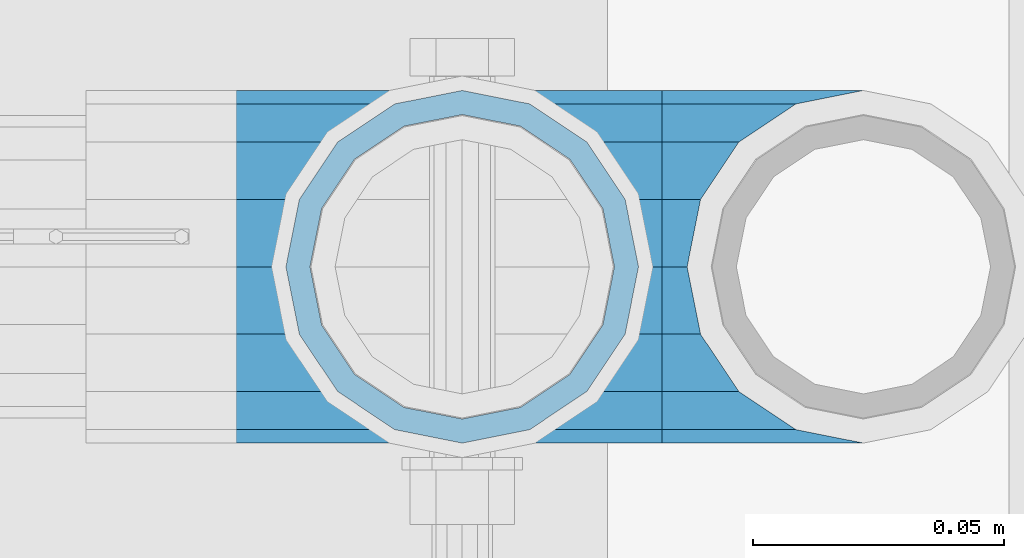
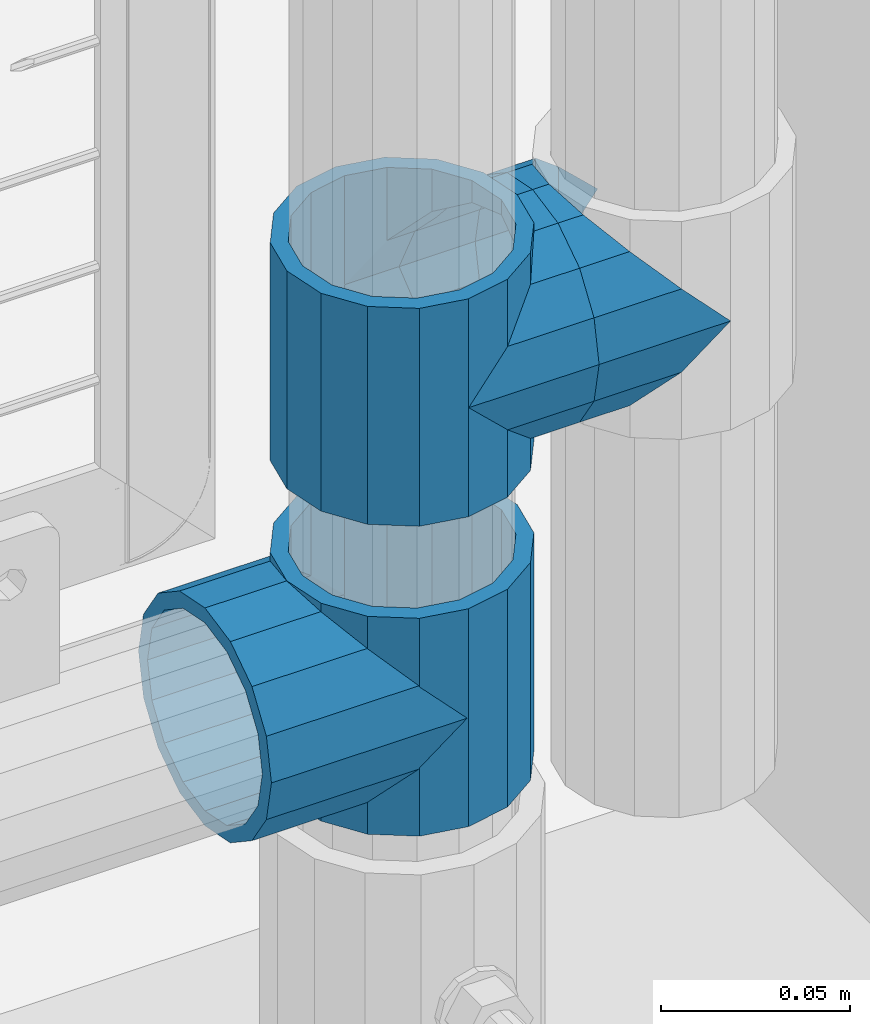
# One storey, part 162 of 240: 5 beams.
"""IFC2X3 building model written with IfcOpenShell, lengths in millimetres."""

from ifc_helpers import new_model, si_unit, frame, origin_with_axes, place, context, subcontext, project, spatial, faceted_brep, material, type_object, element, save


model = new_model("IFC2X3")

# Units and contexts
model_context = context("Model", 3, precision=1e-05, world=origin_with_axes())
body_context = subcontext(model_context, "Body", "Model", "MODEL_VIEW")
ifc_project = project(units=[si_unit("LENGTHUNIT", "METRE", prefix="MILLI"), si_unit("AREAUNIT", "SQUARE_METRE"), si_unit("VOLUMEUNIT", "CUBIC_METRE"), si_unit("MASSUNIT", "GRAM", prefix="KILO"), si_unit("TIMEUNIT", "SECOND"), si_unit("PLANEANGLEUNIT", "RADIAN"), si_unit("SOLIDANGLEUNIT", "STERADIAN"), si_unit("THERMODYNAMICTEMPERATUREUNIT", "DEGREE_CELSIUS"), si_unit("LUMINOUSINTENSITYUNIT", "LUMEN")], contexts=[model_context])

# Site, building, storey
site_placement = place(None, origin_with_axes())
site = spatial("IfcSite", under=ifc_project, at=site_placement, CompositionType="ELEMENT")
building_placement = place(site_placement, origin_with_axes())
building = spatial("IfcBuilding", under=site, at=building_placement, Name="Standard", CompositionType="ELEMENT")
storey_placement = place(building_placement, origin_with_axes())
storey = spatial("IfcBuildingStorey", under=building, at=storey_placement, Name="Undefined", CompositionType="ELEMENT", Elevation=0.0)

# Beams
ifc_material = material(Name="Misc_Undefined")
beam_type = type_object("IfcBeamType", PredefinedType="NOTDEFINED")
beam_1_placement = place(storey_placement, frame((55881.0, 34664.5, 298.670000000001), z_axis=(0.0, 1.0, 0.0), x_axis=(-1.0, 0.0, 0.0)))
element("IfcBeam", 1, at=beam_1_placement, inside=storey, type_object=beam_type, material=ifc_material, context=body_context, shape_type="Brep", body=[
    faceted_brep([(0.0, 0.0, -35.1500000000015), (13.4513226476338, -13.4513226476329, -32.4743655677739), (13.4513226476338, 13.4513226476329, -32.4743655677739), (27.1226768591005, -21.4606908090117, 21.4606908090136), (32.4743655677739, -26.8123795176712, 13.4513226476338), (32.4743655677739, -32.4743655677717, 13.4513226476338), (24.8548033587067, -24.8548033587072, 24.8548033587067), (24.8548033587067, -16.3810424080078, 24.8548033587067), (32.8397438117099, -28.0397438117175, 11.6144421722784), (35.1500000000015, -30.35, 0.0), (35.1500000000015, -35.15, 0.0), (32.4743655677739, -26.8123795176712, -13.4513226476338), (32.4743655677739, -32.4743655677717, -13.4513226476338), (32.8397438117172, -28.0397438117175, -11.6144421722784), (24.8548033587067, -16.3810424079947, -24.8548033587067), (24.8548033587067, -24.8548033587072, -24.8548033587067), (27.1226768591223, -21.4606908090117, -21.4606908090136), (20.0882031229994, -11.6144421722805, -28.0397438117143), (16.6306603983758, 0.0, -30.3499999999985), (20.0882031229994, 11.6144421722805, -28.0397438117143), (24.8548033587067, 16.3810424080013, -24.8548033587067), (24.8548033587067, 24.8548033587072, -24.8548033587067), (27.1226768591223, 21.4606908090117, -21.4606908090136), (32.4743655677739, 26.8123795176712, -13.4513226476338), (32.4743655677739, 32.4743655677717, -13.4513226476338), (32.8397438117172, 28.0397438117175, -11.6144421722784), (35.1500000000015, 30.35, 0.0), (35.1500000000015, 35.15, 0.0), (32.8397438117099, 28.0397438117175, 11.6144421722784), (32.4743655677739, 26.8123795176755, 13.4513226476338), (32.4743655677739, 32.4743655677717, 13.4513226476338), (27.1226768591005, 21.4606908090117, 21.4606908090136), (24.8548033587067, 16.3810424080013, 24.8548033587067), (24.8548033587067, 24.8548033587072, 24.8548033587067), (0.0, 0.0, 35.1500000000015), (13.4513226476338, 13.4513226476329, 32.4743655677739), (13.4513226476338, -13.4513226476329, 32.4743655677739), (20.0882031229849, 11.6144421722805, 28.0397438117143), (16.6306603983685, 0.0, 30.3499999999985), (20.0882031229849, -11.6144421722805, 28.0397438117143), (60.1500000000015, -35.15, 0.0), (60.1500000000015, -32.4743655677717, 13.4513226476338), (60.1500000000015, -24.8548033587072, 24.8548033587067), (60.1500000000015, -13.4513226476329, 32.4743655677739), (60.1500000000015, 0.0, 35.1500000000015), (60.1500000000015, -24.8548033587072, -24.8548033587067), (60.1500000000015, -32.4743655677717, -13.4513226476338), (60.1500000000015, -13.4513226476329, -32.4743655677739), (60.1500000000015, 0.0, -35.1500000000015), (60.1500000000015, 13.4513226476329, -32.4743655677739), (60.1500000000015, 24.8548033587072, -24.8548033587067), (60.1500000000015, 32.4743655677717, -13.4513226476338), (60.1500000000015, 35.15, 0.0), (60.1500000000015, 32.4743655677717, 13.4513226476338), (60.1500000000015, 24.8548033587072, 24.8548033587067), (60.1500000000015, 13.4513226476329, 32.4743655677739), (60.1500000000015, -21.4606908090117, 21.4606908090136), (60.1500000000015, -11.6144421722805, 28.0397438117143), (60.1500000000015, 0.0, 30.3499999999985), (60.1500000000015, 11.6144421722805, 28.0397438117143), (60.1500000000015, 21.4606908090117, 21.4606908090136), (60.1500000000015, 28.0397438117175, 11.6144421722784), (60.1500000000015, 30.35, 0.0), (60.1500000000015, 28.0397438117175, -11.6144421722784), (60.1500000000015, 21.4606908090117, -21.4606908090136), (60.1500000000015, 11.6144421722805, -28.0397438117143), (60.1500000000015, 0.0, -30.3499999999985), (60.1500000000015, -11.6144421722805, -28.0397438117143), (60.1500000000015, -21.4606908090117, -21.4606908090136), (60.1500000000015, -28.0397438117175, -11.6144421722784), (60.1500000000015, -30.35, 0.0), (60.1500000000015, -28.0397438117175, 11.6144421722784)], [[[0, 1, 2]], [[3, 4, 5, 6, 7]], [[8, 9, 10, 5, 4]], [[11, 12, 10, 9, 13]], [[14, 15, 12, 11, 16]], [[2, 1, 15, 14, 17, 18, 19, 20, 21]], [[21, 20, 22, 23, 24]], [[24, 23, 25, 26, 27]], [[27, 26, 28, 29, 30]], [[30, 29, 31, 32, 33]], [[34, 35, 36]], [[33, 32, 37, 38, 39, 7, 6, 36, 35]], [[40, 41, 5, 10]], [[41, 42, 6, 5]], [[42, 43, 36, 6]], [[43, 44, 34, 36]], [[45, 46, 12, 15]], [[47, 45, 15, 1]], [[48, 47, 1, 0]], [[49, 48, 0, 2]], [[50, 49, 2, 21]], [[51, 50, 21, 24]], [[52, 51, 24, 27]], [[53, 52, 27, 30]], [[54, 53, 30, 33]], [[55, 54, 33, 35]], [[44, 55, 35, 34]], [[46, 40, 10, 12]], [[45, 47, 48, 49, 50, 51, 52, 53, 54, 55, 44, 43, 42, 41, 40, 46], [56, 57, 58, 59, 60, 61, 62, 63, 64, 65, 66, 67, 68, 69, 70, 71]], [[59, 58, 38, 37]], [[31, 60, 59, 37, 32]], [[28, 61, 60, 31, 29]], [[62, 61, 28, 26]], [[63, 62, 26, 25]], [[64, 63, 25, 23, 22]], [[65, 64, 22, 20, 19]], [[66, 65, 19, 18]], [[67, 66, 18, 17]], [[16, 68, 67, 17, 14]], [[13, 69, 68, 16, 11]], [[70, 69, 13, 9]], [[71, 70, 9, 8]], [[56, 71, 8, 4, 3]], [[57, 56, 3, 7, 39]], [[58, 57, 39, 38]]]),
])
beam_2_placement = place(storey_placement, frame((55881.0, 34664.5, 333.820000000001), z_axis=(1.0, 0.0, 0.0), x_axis=(0.0, 0.0, -1.0)))
element("IfcBeam", 2, at=beam_2_placement, inside=storey, type_object=beam_type, material=ifc_material, context=body_context, shape_type="Brep", body=[
    faceted_brep([(46.7644421722801, 28.0397438117143, -11.6144421722784), (46.7644421722801, 28.0397438117143, -20.0882031229849), (51.5310424079941, 24.8548033587067, -24.8548033587067), (56.6106908090114, 21.4606908090136, -27.1226768591077), (56.6106908090114, 21.4606908090136, -21.4606908090136), (61.9623795176703, 13.4513226476338, -32.4743655677739), (63.1897438117172, 11.6144421722784, -32.8397438117172), (63.1897438117172, 11.6144421722784, -28.0397438117143), (65.4999999999997, 0.0, -35.1500000000015), (65.4999999999997, 0.0, -30.3499999999985), (63.1897438117172, -11.6144421722784, -32.8397438117245), (63.1897438117172, -11.6144421722784, -28.0397438117143), (61.9623795176703, -13.4513226476338, -32.4743655677739), (56.6106908090114, -21.4606908090136, -27.1226768591223), (56.6106908090114, -21.4606908090136, -21.4606908090136), (51.5310424080006, -24.8548033587067, -24.8548033587067), (46.7644421722801, -28.0397438117143, -20.0882031229994), (46.7644421722801, -28.0397438117143, -11.6144421722784), (35.1499999999996, -30.3499999999985, -16.6306603983758), (35.1500000000015, -30.35, 0.0), (23.5355578277191, -28.0397438117143, -20.0882031229994), (23.5355578277191, -28.0397438117143, -11.6144421722784), (18.7689575919987, -24.8548033587067, -24.8548033587067), (13.6893091909879, -21.4606908090136, -27.1226768591223), (13.6893091909879, -21.4606908090136, -21.4606908090136), (8.33762048232455, -13.4513226476338, -32.4743655677739), (7.11025618828211, -11.6144421722784, -32.8397438117245), (7.11025618828211, -11.6144421722784, -28.0397438117143), (4.79999999999961, 0.0, -35.1500000000015), (4.79999999999961, 0.0, -30.3499999999985), (7.11025618828211, 11.6144421722784, -32.8397438117172), (7.11025618828211, 11.6144421722784, -28.0397438117143), (8.33762048232893, 13.4513226476338, -32.4743655677739), (13.6893091909879, 21.4606908090136, -27.1226768591077), (13.6893091909879, 21.4606908090136, -21.4606908090136), (18.7689575919921, 24.8548033587067, -24.8548033587067), (23.5355578277192, 28.0397438117143, -20.0882031229849), (23.5355578277192, 28.0397438117143, -11.6144421722784), (35.1499999999996, 30.3499999999985, -16.6306603983685), (35.1500000000015, 30.35, 0.0), (0.0, 32.4743655677739, -13.4513226476338), (0.0, 35.1500000000015, 0.0), (70.2999999999993, 35.1500000000015, 0.0), (70.2999999999993, 32.4743655677739, -13.4513226476338), (0.0, 32.4743655677739, 13.4513226476338), (70.2999999999993, 32.4743655677739, 13.4513226476338), (0.0, 24.8548033587067, 24.8548033587067), (70.2999999999993, 24.8548033587067, 24.8548033587067), (0.0, 13.4513226476338, 32.4743655677739), (70.2999999999993, 13.4513226476338, 32.4743655677739), (0.0, 0.0, 35.1500000000015), (70.2999999999993, 0.0, 35.1500000000015), (0.0, -13.4513226476338, 32.4743655677739), (70.2999999999993, -13.4513226476338, 32.4743655677739), (0.0, -24.8548033587067, 24.8548033587067), (70.2999999999993, -24.8548033587067, 24.8548033587067), (0.0, -32.4743655677739, 13.4513226476338), (70.2999999999993, -32.4743655677739, 13.4513226476338), (0.0, -35.1500000000015, 0.0), (70.2999999999993, -35.1500000000015, 0.0), (70.2999999999993, -30.3499999999985, 0.0), (70.2999999999993, -28.0397438117143, -11.6144421722784), (70.2999999999993, -21.4606908090136, -21.4606908090136), (70.2999999999993, -11.6144421722784, -28.0397438117143), (70.2999999999993, 0.0, -30.3499999999985), (70.2999999999993, 11.6144421722784, -28.0397438117143), (70.2999999999993, 21.4606908090136, -21.4606908090136), (70.2999999999993, 28.0397438117143, -11.6144421722784), (0.0, -28.0397438117143, -11.6144421722784), (0.0, -30.3499999999985, 0.0), (0.0, -21.4606908090136, -21.4606908090136), (0.0, -11.6144421722784, -28.0397438117143), (0.0, 0.0, -30.3499999999985), (0.0, 11.6144421722784, -28.0397438117143), (0.0, 21.4606908090136, -21.4606908090136), (0.0, 28.0397438117143, -11.6144421722784), (0.0, 30.3499999999985, 0.0), (70.2999999999993, 30.3499999999985, 0.0), (0.0, 28.0397438117143, 11.6144421722784), (70.2999999999993, 28.0397438117143, 11.6144421722784), (0.0, 21.4606908090136, 21.4606908090136), (70.2999999999993, 21.4606908090136, 21.4606908090136), (0.0, 11.6144421722784, 28.0397438117143), (70.2999999999993, 11.6144421722784, 28.0397438117143), (0.0, 0.0, 30.3499999999985), (70.2999999999993, 0.0, 30.3499999999985), (0.0, -11.6144421722784, 28.0397438117143), (70.2999999999993, -11.6144421722784, 28.0397438117143), (0.0, -21.4606908090136, 21.4606908090136), (70.2999999999993, -21.4606908090136, 21.4606908090136), (0.0, -28.0397438117143, 11.6144421722784), (70.2999999999993, -28.0397438117143, 11.6144421722784), (70.2999999999993, -24.8548033587067, -24.8548033587067), (70.2999999999993, -13.4513226476338, -32.4743655677739), (70.2999999999993, 0.0, -35.1500000000015), (70.2999999999993, 13.4513226476338, -32.4743655677739), (70.2999999999993, 24.8548033587067, -24.8548033587067), (70.2999999999993, -32.4743655677739, -13.4513226476338), (0.0, -32.4743655677739, -13.4513226476338), (0.0, 24.8548033587067, -24.8548033587067), (0.0, 13.4513226476338, -32.4743655677739), (0.0, 0.0, -35.1500000000015), (0.0, -13.4513226476338, -32.4743655677739), (0.0, -24.8548033587067, -24.8548033587067)], [[[0, 1, 2, 3, 4]], [[4, 3, 5, 6, 7]], [[7, 6, 8, 9]], [[9, 8, 10, 11]], [[11, 10, 12, 13, 14]], [[14, 13, 15, 16, 17]], [[17, 16, 18, 19]], [[19, 18, 20, 21]], [[21, 20, 22, 23, 24]], [[24, 23, 25, 26, 27]], [[27, 26, 28, 29]], [[29, 28, 30, 31]], [[31, 30, 32, 33, 34]], [[34, 33, 35, 36, 37]], [[37, 36, 38, 39]], [[39, 38, 1, 0]], [[40, 41, 42, 43]], [[41, 44, 45, 42]], [[44, 46, 47, 45]], [[46, 48, 49, 47]], [[48, 50, 51, 49]], [[50, 52, 53, 51]], [[52, 54, 55, 53]], [[54, 56, 57, 55]], [[56, 58, 59, 57]], [[60, 61, 17, 19]], [[61, 62, 14, 17]], [[62, 63, 11, 14]], [[63, 64, 9, 11]], [[64, 65, 7, 9]], [[65, 66, 4, 7]], [[66, 67, 0, 4]], [[68, 69, 19, 21]], [[70, 68, 21, 24]], [[71, 70, 24, 27]], [[72, 71, 27, 29]], [[73, 72, 29, 31]], [[74, 73, 31, 34]], [[75, 74, 34, 37]], [[76, 75, 37, 39]], [[67, 77, 39, 0]], [[78, 76, 39, 77, 79]], [[80, 78, 79, 81]], [[82, 80, 81, 83]], [[84, 82, 83, 85]], [[86, 84, 85, 87]], [[88, 86, 87, 89]], [[90, 88, 89, 91]], [[19, 69, 90, 91, 60]], [[92, 93, 94, 95, 96, 43, 42, 45, 47, 49, 51, 53, 55, 57, 59, 97], [89, 87, 85, 83, 81, 79, 77, 67, 66, 65, 64, 63, 62, 61, 60, 91]], [[58, 98, 97, 59]], [[56, 54, 52, 50, 48, 46, 44, 41, 40, 99, 100, 101, 102, 103, 98, 58], [68, 70, 71, 72, 73, 74, 75, 76, 78, 80, 82, 84, 86, 88, 90, 69]], [[32, 100, 99, 35, 33]], [[28, 101, 100, 32, 30]], [[102, 101, 28, 26, 25]], [[103, 102, 25, 23, 22]], [[15, 92, 97, 98, 103, 22, 20, 18, 16]], [[12, 93, 92, 15, 13]], [[8, 94, 93, 12, 10]], [[95, 94, 8, 6, 5]], [[96, 95, 5, 3, 2]], [[35, 99, 40, 43, 96, 2, 1, 38, 36]]]),
])
beam_3_placement = place(storey_placement, frame((55881.0, 34664.5, 398.669999999999), z_axis=(0.0, -1.0, 0.0), x_axis=(1.0, 0.0, 0.0)))
element("IfcBeam", 3, at=beam_3_placement, inside=storey, type_object=beam_type, material=ifc_material, context=body_context, shape_type="Brep", body=[
    faceted_brep([(0.0, 0.0, -35.1500000000015), (13.4513226476338, -13.4513226476329, -32.4743655677739), (13.4513226476338, 13.4513226476329, -32.4743655677739), (32.4743655677739, 32.4743655677717, 13.4513226476338), (32.4743655677739, 26.8123795176755, 13.4513226476338), (27.1226768591005, 21.4606908090117, 21.4606908090136), (24.8548033587067, 16.3810424080013, 24.8548033587067), (24.8548033587067, 24.8548033587072, 24.8548033587067), (0.0, 0.0, 35.1500000000015), (13.4513226476338, 13.4513226476329, 32.4743655677739), (13.4513226476338, -13.4513226476329, 32.4743655677739), (20.0882031229849, 11.6144421722805, 28.0397438117143), (16.6306603983685, 0.0, 30.3499999999985), (20.0882031229849, -11.6144421722805, 28.0397438117143), (24.8548033587067, -16.3810424080078, 24.8548033587067), (24.8548033587067, -24.8548033587072, 24.8548033587067), (27.1226768591005, -21.4606908090117, 21.4606908090136), (32.4743655677739, -26.8123795176712, 13.4513226476338), (32.4743655677739, -32.4743655677717, 13.4513226476338), (32.8397438117099, -28.0397438117175, 11.6144421722784), (35.1500000000015, -30.35, 0.0), (35.1500000000015, -35.15, 0.0), (32.4743655677739, -26.8123795176712, -13.4513226476338), (32.4743655677739, -32.4743655677717, -13.4513226476338), (32.8397438117172, -28.0397438117175, -11.6144421722784), (24.8548033587067, -16.3810424079947, -24.8548033587067), (24.8548033587067, -24.8548033587072, -24.8548033587067), (27.1226768591223, -21.4606908090117, -21.4606908090136), (20.0882031229994, -11.6144421722805, -28.0397438117143), (16.6306603983758, 0.0, -30.3499999999985), (20.0882031229994, 11.6144421722805, -28.0397438117143), (24.8548033587067, 16.3810424080013, -24.8548033587067), (24.8548033587067, 24.8548033587072, -24.8548033587067), (27.1226768591223, 21.4606908090117, -21.4606908090136), (32.4743655677739, 26.8123795176712, -13.4513226476338), (32.4743655677739, 32.4743655677717, -13.4513226476338), (32.8397438117172, 28.0397438117175, -11.6144421722784), (35.1500000000015, 30.35, 0.0), (35.1500000000015, 35.15, 0.0), (32.8397438117099, 28.0397438117175, 11.6144421722784), (40.1500000000015, -35.15, 0.0), (40.1500000000015, -32.4743655677717, 13.4513226476338), (40.1500000000015, -24.8548033587072, 24.8548033587067), (40.1500000000015, -13.4513226476329, 32.4743655677739), (40.1500000000015, 0.0, 35.1500000000015), (40.1500000000015, 13.4513226476329, 32.4743655677739), (40.1500000000015, 24.8548033587072, 24.8548033587067), (40.1500000000015, 32.4743655677717, 13.4513226476338), (40.1500000000015, 35.15, 0.0), (40.1500000000015, -24.8548033587072, -24.8548033587067), (40.1500000000015, -32.4743655677717, -13.4513226476338), (40.1500000000015, -13.4513226476329, -32.4743655677739), (40.1500000000015, 0.0, -35.1500000000015), (40.1500000000015, 13.4513226476329, -32.4743655677739), (40.1500000000015, 24.8548033587072, -24.8548033587067), (40.1500000000015, 32.4743655677717, -13.4513226476338), (40.1500000000015, -21.4606908090117, 21.4606908090136), (40.1500000000015, -11.6144421722805, 28.0397438117143), (40.1500000000015, 0.0, 30.3499999999985), (40.1500000000015, 11.6144421722805, 28.0397438117143), (40.1500000000015, 21.4606908090117, 21.4606908090136), (40.1500000000015, 28.0397438117175, 11.6144421722784), (40.1500000000015, 30.35, 0.0), (40.1500000000015, 28.0397438117175, -11.6144421722784), (40.1500000000015, 21.4606908090117, -21.4606908090136), (40.1500000000015, 11.6144421722805, -28.0397438117143), (40.1500000000015, 0.0, -30.3499999999985), (40.1500000000015, -11.6144421722805, -28.0397438117143), (40.1500000000015, -21.4606908090117, -21.4606908090136), (40.1500000000015, -28.0397438117175, -11.6144421722784), (40.1500000000015, -30.35, 0.0), (40.1500000000015, -28.0397438117175, 11.6144421722784)], [[[0, 1, 2]], [[3, 4, 5, 6, 7]], [[8, 9, 10]], [[7, 6, 11, 12, 13, 14, 15, 10, 9]], [[16, 17, 18, 15, 14]], [[19, 20, 21, 18, 17]], [[22, 23, 21, 20, 24]], [[25, 26, 23, 22, 27]], [[2, 1, 26, 25, 28, 29, 30, 31, 32]], [[32, 31, 33, 34, 35]], [[35, 34, 36, 37, 38]], [[38, 37, 39, 4, 3]], [[40, 41, 18, 21]], [[41, 42, 15, 18]], [[42, 43, 10, 15]], [[43, 44, 8, 10]], [[44, 45, 9, 8]], [[45, 46, 7, 9]], [[46, 47, 3, 7]], [[47, 48, 38, 3]], [[49, 50, 23, 26]], [[51, 49, 26, 1]], [[52, 51, 1, 0]], [[53, 52, 0, 2]], [[54, 53, 2, 32]], [[55, 54, 32, 35]], [[48, 55, 35, 38]], [[50, 40, 21, 23]], [[49, 51, 52, 53, 54, 55, 48, 47, 46, 45, 44, 43, 42, 41, 40, 50], [56, 57, 58, 59, 60, 61, 62, 63, 64, 65, 66, 67, 68, 69, 70, 71]], [[63, 62, 37, 36]], [[33, 64, 63, 36, 34]], [[30, 65, 64, 33, 31]], [[66, 65, 30, 29]], [[67, 66, 29, 28]], [[68, 67, 28, 25, 27]], [[69, 68, 27, 22, 24]], [[70, 69, 24, 20]], [[71, 70, 20, 19]], [[16, 56, 71, 19, 17]], [[13, 57, 56, 16, 14]], [[58, 57, 13, 12]], [[59, 58, 12, 11]], [[60, 59, 11, 6, 5]], [[61, 60, 5, 4, 39]], [[62, 61, 39, 37]]]),
])
beam_4_placement = place(storey_placement, frame((55961.0, 34664.5, 398.669999999999), z_axis=(0.0, 1.0, 0.0), x_axis=(-1.0, 0.0, 0.0)))
element("IfcBeam", 4, at=beam_4_placement, inside=storey, type_object=beam_type, material=ifc_material, context=body_context, shape_type="Brep", body=[
    faceted_brep([(0.0, 0.0, -35.1500000000015), (13.4513226476338, -13.4513226476329, -32.4743655677739), (13.4513226476338, 13.4513226476329, -32.4743655677739), (27.1226768591005, -21.4606908090117, 21.4606908090136), (32.4743655677739, -26.8123795176712, 13.4513226476338), (32.4743655677739, -32.4743655677717, 13.4513226476338), (24.8548033587067, -24.8548033587072, 24.8548033587067), (24.8548033587067, -16.3810424080078, 24.8548033587067), (32.8397438117099, -28.0397438117175, 11.6144421722784), (35.1500000000015, -30.35, 0.0), (35.1500000000015, -35.15, 0.0), (32.4743655677739, -26.8123795176712, -13.4513226476338), (32.4743655677739, -32.4743655677717, -13.4513226476338), (32.8397438117172, -28.0397438117175, -11.6144421722784), (24.8548033587067, -16.3810424079947, -24.8548033587067), (24.8548033587067, -24.8548033587072, -24.8548033587067), (27.1226768591223, -21.4606908090117, -21.4606908090136), (20.0882031229994, -11.6144421722805, -28.0397438117143), (16.6306603983758, 0.0, -30.3499999999985), (20.0882031229994, 11.6144421722805, -28.0397438117143), (24.8548033587067, 16.3810424080013, -24.8548033587067), (24.8548033587067, 24.8548033587072, -24.8548033587067), (27.1226768591223, 21.4606908090117, -21.4606908090136), (32.4743655677739, 26.8123795176712, -13.4513226476338), (32.4743655677739, 32.4743655677717, -13.4513226476338), (32.8397438117172, 28.0397438117175, -11.6144421722784), (35.1500000000015, 30.35, 0.0), (35.1500000000015, 35.15, 0.0), (32.8397438117099, 28.0397438117175, 11.6144421722784), (32.4743655677739, 26.8123795176755, 13.4513226476338), (32.4743655677739, 32.4743655677717, 13.4513226476338), (27.1226768591005, 21.4606908090117, 21.4606908090136), (24.8548033587067, 16.3810424080013, 24.8548033587067), (24.8548033587067, 24.8548033587072, 24.8548033587067), (0.0, 0.0, 35.1500000000015), (13.4513226476338, 13.4513226476329, 32.4743655677739), (13.4513226476338, -13.4513226476329, 32.4743655677739), (20.0882031229849, 11.6144421722805, 28.0397438117143), (16.6306603983685, 0.0, 30.3499999999985), (20.0882031229849, -11.6144421722805, 28.0397438117143), (40.1500000000015, -35.15, 0.0), (40.1500000000015, -32.4743655677717, 13.4513226476338), (40.1500000000015, -24.8548033587072, 24.8548033587067), (40.1500000000015, -13.4513226476329, 32.4743655677739), (40.1500000000015, 0.0, 35.1500000000015), (40.1500000000015, -24.8548033587072, -24.8548033587067), (40.1500000000015, -32.4743655677717, -13.4513226476338), (40.1500000000015, -13.4513226476329, -32.4743655677739), (40.1500000000015, 0.0, -35.1500000000015), (40.1500000000015, 13.4513226476329, -32.4743655677739), (40.1500000000015, 24.8548033587072, -24.8548033587067), (40.1500000000015, 32.4743655677717, -13.4513226476338), (40.1500000000015, 35.15, 0.0), (40.1500000000015, 32.4743655677717, 13.4513226476338), (40.1500000000015, 24.8548033587072, 24.8548033587067), (40.1500000000015, 13.4513226476329, 32.4743655677739), (40.1500000000015, -21.4606908090117, 21.4606908090136), (40.1500000000015, -11.6144421722805, 28.0397438117143), (40.1500000000015, 0.0, 30.3499999999985), (40.1500000000015, 11.6144421722805, 28.0397438117143), (40.1500000000015, 21.4606908090117, 21.4606908090136), (40.1500000000015, 28.0397438117175, 11.6144421722784), (40.1500000000015, 30.35, 0.0), (40.1500000000015, 28.0397438117175, -11.6144421722784), (40.1500000000015, 21.4606908090117, -21.4606908090136), (40.1500000000015, 11.6144421722805, -28.0397438117143), (40.1500000000015, 0.0, -30.3499999999985), (40.1500000000015, -11.6144421722805, -28.0397438117143), (40.1500000000015, -21.4606908090117, -21.4606908090136), (40.1500000000015, -28.0397438117175, -11.6144421722784), (40.1500000000015, -30.35, 0.0), (40.1500000000015, -28.0397438117175, 11.6144421722784)], [[[0, 1, 2]], [[3, 4, 5, 6, 7]], [[8, 9, 10, 5, 4]], [[11, 12, 10, 9, 13]], [[14, 15, 12, 11, 16]], [[2, 1, 15, 14, 17, 18, 19, 20, 21]], [[21, 20, 22, 23, 24]], [[24, 23, 25, 26, 27]], [[27, 26, 28, 29, 30]], [[30, 29, 31, 32, 33]], [[34, 35, 36]], [[33, 32, 37, 38, 39, 7, 6, 36, 35]], [[40, 41, 5, 10]], [[41, 42, 6, 5]], [[42, 43, 36, 6]], [[43, 44, 34, 36]], [[45, 46, 12, 15]], [[47, 45, 15, 1]], [[48, 47, 1, 0]], [[49, 48, 0, 2]], [[50, 49, 2, 21]], [[51, 50, 21, 24]], [[52, 51, 24, 27]], [[53, 52, 27, 30]], [[54, 53, 30, 33]], [[55, 54, 33, 35]], [[44, 55, 35, 34]], [[46, 40, 10, 12]], [[45, 47, 48, 49, 50, 51, 52, 53, 54, 55, 44, 43, 42, 41, 40, 46], [56, 57, 58, 59, 60, 61, 62, 63, 64, 65, 66, 67, 68, 69, 70, 71]], [[59, 58, 38, 37]], [[60, 59, 37, 32, 31]], [[61, 60, 31, 29, 28]], [[62, 61, 28, 26]], [[63, 62, 26, 25]], [[22, 64, 63, 25, 23]], [[19, 65, 64, 22, 20]], [[66, 65, 19, 18]], [[67, 66, 18, 17]], [[68, 67, 17, 14, 16]], [[69, 68, 16, 11, 13]], [[70, 69, 13, 9]], [[71, 70, 9, 8]], [[3, 56, 71, 8, 4]], [[39, 57, 56, 3, 7]], [[58, 57, 39, 38]]]),
])
beam_5_placement = place(storey_placement, frame((55881.0, 34664.5, 433.819999999999), z_axis=(-1.0, 0.0, 0.0), x_axis=(0.0, 0.0, -1.0)))
element("IfcBeam", 5, at=beam_5_placement, inside=storey, type_object=beam_type, material=ifc_material, context=body_context, shape_type="Brep", body=[
    faceted_brep([(13.6893091909879, -21.4606908090136, -21.4606908090136), (13.6893091909879, -21.4606908090136, -27.1226768591223), (8.33762048232455, -13.4513226476338, -32.4743655677739), (7.11025618828211, -11.6144421722784, -32.8397438117245), (7.11025618828211, -11.6144421722784, -28.0397438117143), (23.5355578277191, -28.0397438117143, -11.6144421722784), (23.5355578277191, -28.0397438117143, -20.0882031229994), (18.7689575919987, -24.8548033587067, -24.8548033587067), (35.1500000000015, -30.35, 0.0), (35.1499999999996, -30.3499999999985, -16.6306603983758), (46.7644421722801, -28.0397438117143, -11.6144421722784), (46.7644421722801, -28.0397438117143, -20.0882031229994), (56.6106908090114, -21.4606908090136, -21.4606908090136), (56.6106908090114, -21.4606908090136, -27.1226768591223), (51.5310424080006, -24.8548033587067, -24.8548033587067), (63.1897438117172, -11.6144421722784, -28.0397438117143), (63.1897438117172, -11.6144421722784, -32.8397438117245), (61.9623795176703, -13.4513226476338, -32.4743655677739), (65.4999999999997, 0.0, -30.3499999999985), (65.4999999999997, 0.0, -35.1500000000015), (63.1897438117172, 11.6144421722784, -28.0397438117143), (63.1897438117172, 11.6144421722784, -32.8397438117172), (56.6106908090114, 21.4606908090136, -21.4606908090136), (56.6106908090114, 21.4606908090136, -27.1226768591077), (61.9623795176703, 13.4513226476338, -32.4743655677739), (46.7644421722801, 28.0397438117143, -11.6144421722784), (46.7644421722801, 28.0397438117143, -20.0882031229849), (51.5310424079941, 24.8548033587067, -24.8548033587067), (35.1500000000015, 30.35, 0.0), (35.1499999999996, 30.3499999999985, -16.6306603983685), (23.5355578277192, 28.0397438117143, -11.6144421722784), (23.5355578277192, 28.0397438117143, -20.0882031229849), (13.6893091909879, 21.4606908090136, -21.4606908090136), (13.6893091909879, 21.4606908090136, -27.1226768591077), (18.7689575919921, 24.8548033587067, -24.8548033587067), (7.11025618828211, 11.6144421722784, -28.0397438117143), (7.11025618828211, 11.6144421722784, -32.8397438117172), (8.33762048232893, 13.4513226476338, -32.4743655677739), (4.79999999999961, 0.0, -30.3499999999985), (4.79999999999961, 0.0, -35.1500000000015), (0.0, 21.4606908090136, 21.4606908090136), (0.0, 28.0397438117143, 11.6144421722784), (70.2999999999993, 28.0397438117143, 11.6144421722784), (70.2999999999993, 21.4606908090136, 21.4606908090136), (0.0, 11.6144421722784, 28.0397438117143), (70.2999999999993, 11.6144421722784, 28.0397438117143), (0.0, 0.0, 30.3499999999985), (70.2999999999993, 0.0, 30.3499999999985), (0.0, -11.6144421722784, 28.0397438117143), (70.2999999999993, -11.6144421722784, 28.0397438117143), (0.0, -21.4606908090136, 21.4606908090136), (70.2999999999993, -21.4606908090136, 21.4606908090136), (0.0, -28.0397438117143, 11.6144421722784), (70.2999999999993, -28.0397438117143, 11.6144421722784), (0.0, -24.8548033587067, -24.8548033587067), (0.0, -13.4513226476338, -32.4743655677739), (0.0, 0.0, -35.1500000000015), (0.0, -32.4743655677739, 13.4513226476338), (0.0, -35.1500000000015, 0.0), (70.2999999999993, -35.1500000000015, 0.0), (70.2999999999993, -32.4743655677739, 13.4513226476338), (0.0, -24.8548033587067, 24.8548033587067), (70.2999999999993, -24.8548033587067, 24.8548033587067), (0.0, -13.4513226476338, 32.4743655677739), (70.2999999999993, -13.4513226476338, 32.4743655677739), (0.0, 0.0, 35.1500000000015), (70.2999999999993, 0.0, 35.1500000000015), (0.0, 13.4513226476338, 32.4743655677739), (70.2999999999993, 13.4513226476338, 32.4743655677739), (0.0, 24.8548033587067, 24.8548033587067), (70.2999999999993, 24.8548033587067, 24.8548033587067), (0.0, 32.4743655677739, 13.4513226476338), (70.2999999999993, 32.4743655677739, 13.4513226476338), (0.0, 35.1500000000015, 0.0), (70.2999999999993, 35.1500000000015, 0.0), (0.0, 32.4743655677739, -13.4513226476338), (70.2999999999993, 32.4743655677739, -13.4513226476338), (70.2999999999993, -13.4513226476338, -32.4743655677739), (70.2999999999993, -24.8548033587067, -24.8548033587067), (70.2999999999993, 0.0, -35.1500000000015), (70.2999999999993, 13.4513226476338, -32.4743655677739), (70.2999999999993, 24.8548033587067, -24.8548033587067), (0.0, 24.8548033587067, -24.8548033587067), (0.0, 13.4513226476338, -32.4743655677739), (70.2999999999993, -32.4743655677739, -13.4513226476338), (0.0, -32.4743655677739, -13.4513226476338), (0.0, -28.0397438117143, -11.6144421722784), (0.0, -21.4606908090136, -21.4606908090136), (0.0, -11.6144421722784, -28.0397438117143), (0.0, 0.0, -30.3499999999985), (0.0, 11.6144421722784, -28.0397438117143), (0.0, 21.4606908090136, -21.4606908090136), (0.0, 28.0397438117143, -11.6144421722784), (0.0, 30.3499999999985, 0.0), (0.0, -30.3499999999985, 0.0), (70.2999999999993, 30.3499999999985, 0.0), (70.2999999999993, 28.0397438117143, -11.6144421722784), (70.2999999999993, 21.4606908090136, -21.4606908090136), (70.2999999999993, 11.6144421722784, -28.0397438117143), (70.2999999999993, 0.0, -30.3499999999985), (70.2999999999993, -11.6144421722784, -28.0397438117143), (70.2999999999993, -21.4606908090136, -21.4606908090136), (70.2999999999993, -28.0397438117143, -11.6144421722784), (70.2999999999993, -30.3499999999985, 0.0)], [[[0, 1, 2, 3, 4]], [[5, 6, 7, 1, 0]], [[8, 9, 6, 5]], [[10, 11, 9, 8]], [[12, 13, 14, 11, 10]], [[15, 16, 17, 13, 12]], [[18, 19, 16, 15]], [[20, 21, 19, 18]], [[22, 23, 24, 21, 20]], [[25, 26, 27, 23, 22]], [[28, 29, 26, 25]], [[30, 31, 29, 28]], [[32, 33, 34, 31, 30]], [[35, 36, 37, 33, 32]], [[38, 39, 36, 35]], [[4, 3, 39, 38]], [[40, 41, 42, 43]], [[44, 40, 43, 45]], [[46, 44, 45, 47]], [[48, 46, 47, 49]], [[50, 48, 49, 51]], [[52, 50, 51, 53]], [[54, 55, 2, 1, 7]], [[55, 56, 39, 3, 2]], [[57, 58, 59, 60]], [[61, 57, 60, 62]], [[63, 61, 62, 64]], [[65, 63, 64, 66]], [[67, 65, 66, 68]], [[69, 67, 68, 70]], [[71, 69, 70, 72]], [[73, 71, 72, 74]], [[75, 73, 74, 76]], [[17, 77, 78, 14, 13]], [[19, 79, 77, 17, 16]], [[80, 79, 19, 21, 24]], [[81, 80, 24, 23, 27]], [[34, 82, 75, 76, 81, 27, 26, 29, 31]], [[37, 83, 82, 34, 33]], [[39, 56, 83, 37, 36]], [[14, 78, 84, 85, 54, 7, 6, 9, 11]], [[58, 85, 84, 59]], [[57, 61, 63, 65, 67, 69, 71, 73, 75, 82, 83, 56, 55, 54, 85, 58], [86, 87, 88, 89, 90, 91, 92, 93, 41, 40, 44, 46, 48, 50, 52, 94]], [[90, 89, 38, 35]], [[91, 90, 35, 32]], [[92, 91, 32, 30]], [[93, 92, 30, 28]], [[41, 93, 28, 95, 42]], [[96, 95, 28, 25]], [[97, 96, 25, 22]], [[98, 97, 22, 20]], [[99, 98, 20, 18]], [[100, 99, 18, 15]], [[101, 100, 15, 12]], [[102, 101, 12, 10]], [[103, 102, 10, 8]], [[78, 77, 79, 80, 81, 76, 74, 72, 70, 68, 66, 64, 62, 60, 59, 84], [51, 49, 47, 45, 43, 42, 95, 96, 97, 98, 99, 100, 101, 102, 103, 53]], [[8, 94, 52, 53, 103]], [[86, 94, 8, 5]], [[87, 86, 5, 0]], [[88, 87, 0, 4]], [[89, 88, 4, 38]]]),
])

save(model, "model.ifc")
